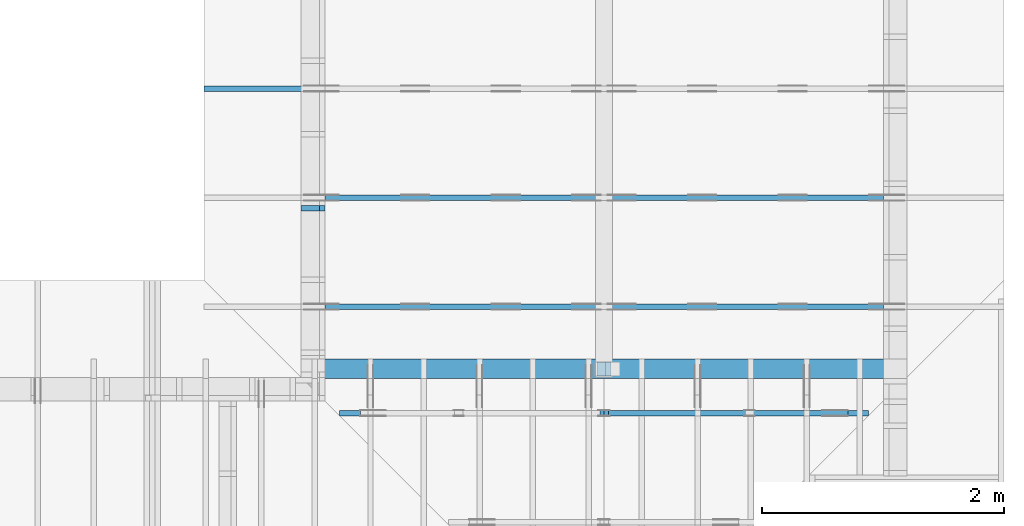
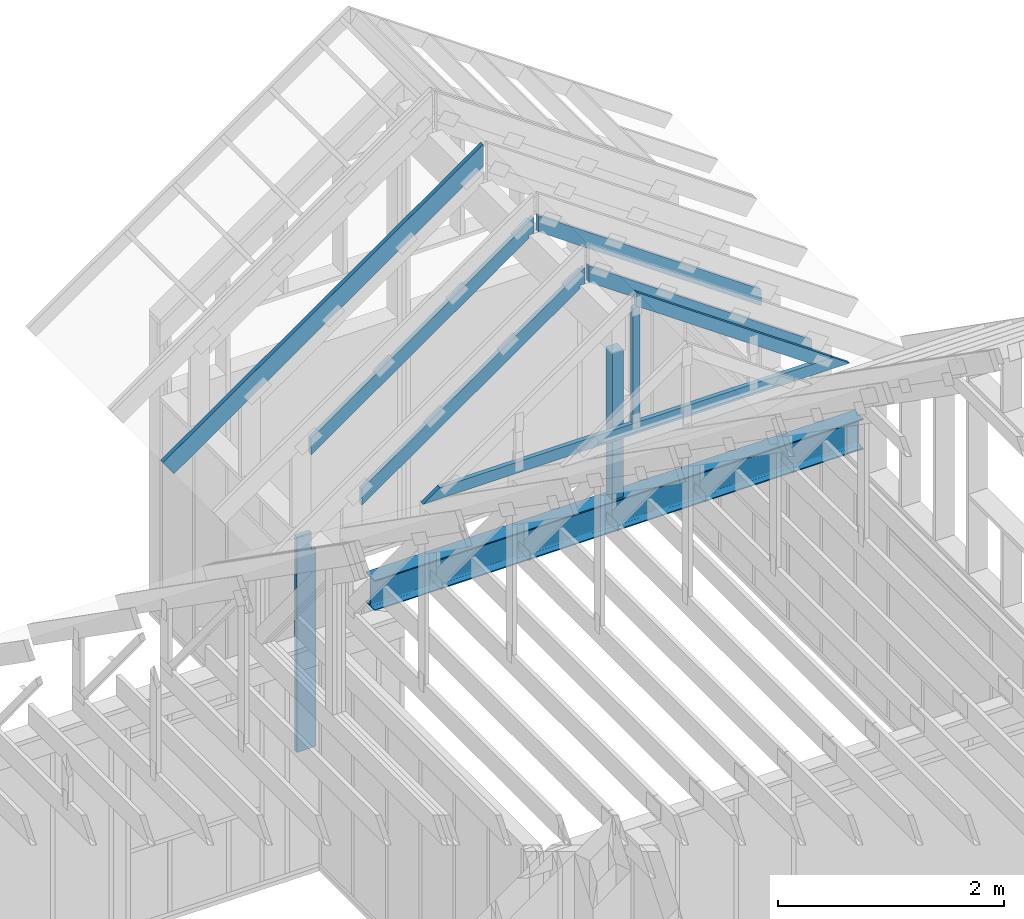
# One storey, part 31 of 70: 11 members, 9 elements without a shape of their own.
"""IFC2X3 building model written with IfcOpenShell, lengths in millimetres."""

from ifc_helpers import new_model, si_unit, frame, origin, origin_with_axes, origin_2d, place, context, project, spatial, faceted_brep, element, aggregate, save


model = new_model("IFC2X3")

# Units and contexts
model_context = context("Model", 3, precision=1e-05, world=origin())
plan_context = context("Plan", 2, precision=1e-05, world=origin_2d())
ifc_project = project(units=[si_unit("LENGTHUNIT", "METRE", prefix="MILLI"), si_unit("AREAUNIT", "SQUARE_METRE"), si_unit("VOLUMEUNIT", "CUBIC_METRE"), si_unit("SOLIDANGLEUNIT", "STERADIAN"), si_unit("PLANEANGLEUNIT", "RADIAN"), si_unit("MASSUNIT", "GRAM"), si_unit("TIMEUNIT", "SECOND"), si_unit("THERMODYNAMICTEMPERATUREUNIT", "DEGREE_CELSIUS"), si_unit("LUMINOUSINTENSITYUNIT", "LUMEN")], contexts=[model_context, plan_context])

# Site, building, storey
site_placement = place(None, origin_with_axes())
site = spatial("IfcSite", under=ifc_project, at=site_placement, CompositionType="ELEMENT")
building_placement = place(site_placement, origin_with_axes())
building = spatial("IfcBuilding", under=site, at=building_placement, Name="Layout 1", CompositionType="ELEMENT")
storey_placement = place(building_placement, origin_with_axes())
storey = spatial("IfcBuildingStorey", under=building, at=storey_placement, Name="Storey 1", CompositionType="ELEMENT", Elevation=0.0)

# Assembly, member
assembly_1_placement = place(storey_placement, frame((12000.0, 8150.0, 4.898425415289509e-15), z_axis=(1.2246063538223773e-16, 1.0, 6.123031769111886e-17), x_axis=(-1.0, 1.2246063538223773e-16, 0.0)))
assembly_1 = element("IfcElementAssembly", 1, at=assembly_1_placement, inside=storey, Name="B3", AssemblyPlace="FACTORY", PredefinedType="TRUSS")
member_1_placement = place(assembly_1_placement, frame((-4.041200967613845e-14, -7.5, -160.0), z_axis=(0.0, 0.0, 1.0), x_axis=(1.0, 0.0, 0.0)))
member_1 = element("IfcMember", 2, at=member_1_placement, Name="G1", context=model_context, shape_type="Brep", body=[
    faceted_brep([(9.796850830579018e-15, 330.0, 0.0), (1.5777218104420236e-30, 330.0, 159.99999999999997), (1.5777218104420236e-30, 318.5, 159.99999999999997), (3.566666005507675e-15, 318.5, 101.74999999999997), (3.851922307918184e-15, 317.88666487320324, 97.0912571881546), (4.117738864727745e-15, 316.0884572681199, 92.74999999999997), (4.346000716872418e-15, 313.22792206135784, 89.02207793864211), (4.521152196349088e-15, 309.5, 86.16154273188008), (4.631257019282926e-15, 305.1587428118454, 84.36333512679674), (4.668811723947815e-15, 300.5, 83.74999999999997), (4.668811723947813e-15, 29.500000000000004, 83.75), (4.631257019282925e-15, 24.841257188154625, 84.36333512679677), (4.5211521963490856e-15, 20.5, 86.1615427318801), (4.346000716872416e-15, 16.772077938642145, 89.02207793864214), (4.1177388647277435e-15, 13.91154273188011, 92.75), (3.851922307918182e-15, 12.11333512679677, 97.09125718815463), (3.566666005507674e-15, 11.5, 101.75), (0.0, 11.5, 160.0), (0.0, 2.930988785010413e-14, 160.0), (9.796850830579018e-15, 2.930988785010413e-14, 0.0), (9.796850830579018e-15, 11.5, 0.0), (6.230184825071344e-15, 11.5, 58.25), (5.944928522660836e-15, 12.11333512679677, 62.90874281184537), (5.6791119658512745e-15, 13.91154273188011, 67.25), (5.450850113706602e-15, 16.772077938642145, 70.97792206135786), (5.2756986342299325e-15, 20.5, 73.8384572681199), (5.1655938112960934e-15, 24.841257188154625, 75.63666487320323), (5.128039106631205e-15, 29.500000000000004, 76.25), (5.128039106631205e-15, 300.5, 76.25), (5.1655938112960934e-15, 305.1587428118454, 75.63666487320323), (5.2756986342299325e-15, 309.5, 73.8384572681199), (5.450850113706602e-15, 313.22792206135784, 70.97792206135786), (5.6791119658512745e-15, 316.0884572681199, 67.25), (5.944928522660836e-15, 317.88666487320324, 62.90874281184537), (6.230184825071344e-15, 318.5, 58.25), (9.796850830579018e-15, 318.5, 0.0), (5000.0, 330.0, 0.0), (5000.0, 330.0, 159.99999999999997), (5000.0, 318.5, 159.99999999999997), (5000.0, 318.5, 101.74999999999997), (5000.0, 317.88666487320324, 97.0912571881546), (5000.0, 316.0884572681199, 92.74999999999997), (5000.0, 313.22792206135784, 89.02207793864211), (5000.0, 309.5, 86.16154273188008), (5000.0, 305.1587428118454, 84.36333512679674), (5000.0, 300.5, 83.74999999999997), (5000.0, 29.500000000000004, 83.75), (5000.0, 24.841257188154625, 84.36333512679677), (5000.0, 20.5, 86.1615427318801), (5000.0, 16.772077938642145, 89.02207793864214), (5000.0, 13.91154273188011, 92.75), (5000.0, 12.11333512679677, 97.09125718815463), (5000.0, 11.5, 101.75), (5000.0, 11.5, 160.0), (5000.0, 2.930988785010413e-14, 160.0), (5000.0, 2.930988785010413e-14, 0.0), (5000.0, 11.5, 0.0), (5000.0, 11.5, 58.25), (5000.0, 12.11333512679677, 62.90874281184537), (5000.0, 13.91154273188011, 67.25), (5000.0, 16.772077938642145, 70.97792206135786), (5000.0, 20.5, 73.8384572681199), (5000.0, 24.841257188154625, 75.63666487320323), (5000.0, 29.500000000000004, 76.25), (5000.0, 300.5, 76.25), (5000.0, 305.1587428118454, 75.63666487320323), (5000.0, 309.5, 73.8384572681199), (5000.0, 313.22792206135784, 70.97792206135786), (5000.0, 316.0884572681199, 67.25), (5000.0, 317.88666487320324, 62.90874281184537), (5000.0, 318.5, 58.25), (5000.0, 318.5, 0.0), (5000.0, 330.0, 0.0), (9.796850830579018e-15, 330.0, 0.0), (9.796850830579018e-15, 318.5, 0.0), (5000.0, 318.5, 0.0), (5000.0, 11.5, 0.0), (9.796850830579018e-15, 11.5, 0.0), (9.796850830579018e-15, 0.0, 0.0), (5000.0, 0.0, 0.0), (5000.0, 11.499999999999082, 5.620633949699709e-29), (5000.0, 11.499999999999085, 58.25), (9.796850830579018e-15, 11.500000000000004, 58.25), (9.796850830579018e-15, 11.5, 0.0), (5000.0, 11.499999999999087, 101.75), (5000.0, 11.49999999999909, 160.0), (9.79685083057902e-15, 11.50000000000001, 160.0), (9.79685083057902e-15, 11.500000000000007, 101.75), (5000.0, 11.499999999999112, 58.250000000000114), (5000.0, 12.113335126795883, 62.908742811845485), (6.3428489390660134e-15, 12.113335126796786, 62.90874281184537), (6.230184825071347e-15, 11.500000000000014, 58.25), (5000.0, 12.113335126795976, 62.9087428118457), (5000.0, 13.911542731879313, 67.25000000000031), (6.275242991462349e-15, 13.911542731880102, 67.25), (5.944928522660833e-15, 12.11333512679676, 62.90874281184538), (5000.0, 13.911542731879532, 67.25000000000045), (5000.0, 16.77207793864157, 70.9779220613583), (6.204566404281285e-15, 16.772077938642145, 70.97792206135786), (5.6791119658512745e-15, 13.911542731880107, 67.25), (5000.0, 16.7720779386418, 70.9779220613583), (5000.0, 20.49999999999966, 73.83845726812035), (6.135635670140619e-15, 20.499999999999993, 73.8384572681199), (5.4508501137066016e-15, 16.77207793864214, 70.97792206135787), (5000.0, 20.49999999999987, 73.83845726812021), (5000.0, 24.841257188154497, 75.63666487320354), (6.073148304658615e-15, 24.841257188154625, 75.63666487320322), (5.275698634229933e-15, 20.500000000000004, 73.8384572681199), (5000.0, 24.841257188154607, 75.63666487320337), (5000.0, 29.499999999999986, 76.25000000000014), (6.0213627185276195e-15, 29.500000000000007, 76.25000000000001), (5.165593811296093e-15, 24.84125718815463, 75.63666487320324), (5000.0, 300.5, 76.25), (5.128039106631205e-15, 300.5, 76.25), (5.128039106631205e-15, 29.500000000000004, 76.25), (5000.0, 29.500000000000004, 76.25), (5.413295409041716e-15, 305.15874281184546, 75.63666487320333), (5000.0, 300.5, 76.25000000000007), (5000.0, 305.1587428118454, 75.6366648732033), (5.4314103681056574e-15, 309.50000000000006, 73.83845726811997), (5000.0, 305.15874281184534, 75.6366648732032), (5000.0, 309.49999999999994, 73.83845726811988), (5.503960486374606e-15, 313.22792206135784, 70.97792206135786), (5000.0, 309.4999999999999, 73.83845726811974), (5000.0, 313.22792206135773, 70.9779220613577), (5.626001593183277e-15, 316.0884572681199, 67.25), (5000.0, 313.2279220613577, 70.9779220613577), (5000.0, 316.0884572681197, 67.24999999999984), (5.789216788785118e-15, 317.8866648732033, 62.9087428118454), (5000.0, 316.0884572681197, 67.24999999999991), (5000.0, 317.8866648732031, 62.90874281184529), (5.982483227325724e-15, 318.5, 58.25), (5000.0, 317.88666487320296, 62.90874281184533), (5000.0, 318.4999999999997, 58.24999999999996), (6.230184825071344e-15, 318.5, 0.0), (6.230184825071344e-15, 318.5, 58.25), (5000.0, 318.4999999999997, 58.25), (5000.0, 318.4999999999997, -1.8932661725304283e-29), (6.230184825071344e-15, 318.5, 101.74999999999997), (6.2301848250713435e-15, 318.5, 159.99999999999997), (5000.0, 318.49999999999966, 159.99999999999997), (5000.0, 318.4999999999997, 101.74999999999997), (5000.0, 329.9999999999991, 5.679798517591285e-29), (5000.0, 329.9999999999991, 159.99999999999997), (9.79685083057902e-15, 330.0, 159.99999999999997), (9.796850830579018e-15, 330.0, 0.0), (0.0, 330.0, 159.99999999999997), (5000.0, 330.0, 160.0000000000006), (5000.0, 318.5, 160.0000000000006), (0.0, 318.5, 159.99999999999997), (3.1554436208840472e-30, 11.500000000000032, 159.99999999999997), (5000.0, 11.500000000000032, 160.0000000000006), (5000.0, 2.930988785010413e-14, 160.0000000000006), (3.1554436208840472e-30, 2.930988785010413e-14, 159.99999999999997), (3.5291113008427863e-15, 317.88666487320324, 97.0912571881546), (5000.0, 318.4999999999997, 101.75), (5000.0, 317.88666487320296, 97.09125718815466), (3.7418174849843445e-15, 316.0884572681199, 92.74999999999999), (5000.0, 317.886664873203, 97.09125718815473), (5000.0, 316.08845726811967, 92.7500000000001), (3.94258738525107e-15, 313.2279220613578, 89.02207793864211), (5000.0, 316.08845726811967, 92.7500000000001), (5000.0, 313.2279220613576, 89.02207793864228), (4.1177388647277396e-15, 309.5, 86.16154273188016), (5000.0, 313.22792206135773, 89.02207793864235), (5000.0, 309.49999999999983, 86.1615427318803), (4.255335639539532e-15, 305.1587428118455, 84.36333512679664), (5000.0, 309.50000000000006, 86.16154273188008), (5000.0, 305.15874281184546, 84.36333512679674), (4.346000716872412e-15, 300.49999999999994, 83.74999999999986), (5000.0, 305.1587428118454, 84.36333512679667), (5000.0, 300.49999999999994, 83.74999999999989), (4.66881172394781e-15, 300.5, 83.75), (5000.0, 300.5, 83.75000000000061), (5000.0, 29.500000000000004, 83.75000000000061), (4.668811723947813e-15, 29.500000000000004, 83.75), (5000.0, 29.499999999999986, 83.74999999999989), (5000.0, 24.84125718815461, 84.36333512679666), (3.8130428167162864e-15, 24.84125718815463, 84.36333512679677), (4.6688117239478125e-15, 29.500000000000007, 83.75), (5000.0, 24.841257188154493, 84.36333512679647), (5000.0, 20.499999999999872, 86.1615427318798), (3.833807348854242e-15, 20.500000000000007, 86.16154273188012), (4.631257019282925e-15, 24.84125718815463, 84.3633351267968), (5000.0, 20.499999999999666, 86.16154273187966), (5000.0, 16.772077938641814, 89.0220779386417), (3.8363666399150676e-15, 16.77207793864215, 89.02207793864214), (4.521152196349085e-15, 20.500000000000004, 86.1615427318801), (5000.0, 16.77207793864156, 89.0220779386417), (5000.0, 13.911542731879528, 92.74999999999955), (3.820546278442408e-15, 13.911542731880111, 92.74999999999999), (4.346000716872415e-15, 16.772077938642134, 89.02207793864214), (5000.0, 13.91154273187933, 92.74999999999969), (5000.0, 12.113335126795995, 97.09125718815432), (3.7874243959262256e-15, 12.113335126796777, 97.09125718815463), (4.117738864727741e-15, 13.911542731880111, 92.75000000000003), (5000.0, 12.113335126795855, 97.0912571881545), (5000.0, 11.499999999999085, 101.74999999999986), (3.7392581939235136e-15, 11.499999999999988, 101.74999999999999), (3.851922307918181e-15, 12.113335126796759, 97.09125718815461), (-1.794653744552941e-30, 1.0988721892453267e-46, 9.646674802900867e-47), (-2.1918016109641297e-31, 2.573028595742599e-14, 160.0), (5000.0, -2.804213024981683e-13, 160.0), (5000.0, -3.061515884555943e-13, 4.92335494830165e-29)], [[[0, 1, 2, 3, 4, 5, 6, 7, 8, 9, 10, 11, 12, 13, 14, 15, 16, 17, 18, 19, 20, 21, 22, 23, 24, 25, 26, 27, 28, 29, 30, 31, 32, 33, 34, 35]], [[36, 37, 38, 39, 40, 41, 42, 43, 44, 45, 46, 47, 48, 49, 50, 51, 52, 53, 54, 55, 56, 57, 58, 59, 60, 61, 62, 63, 64, 65, 66, 67, 68, 69, 70, 71]], [[72, 73, 74, 75]], [[76, 77, 78, 79]], [[80, 81, 82, 83]], [[84, 85, 86, 87]], [[88, 89, 90, 91]], [[92, 93, 94, 95]], [[96, 97, 98, 99]], [[100, 101, 102, 103]], [[104, 105, 106, 107]], [[108, 109, 110, 111]], [[112, 113, 114, 115]], [[116, 117, 118]], [[119, 120, 121]], [[122, 123, 124]], [[125, 126, 127]], [[128, 129, 130]], [[131, 132, 133]], [[134, 135, 136, 137]], [[138, 139, 140, 141]], [[142, 143, 144, 145]], [[146, 147, 148, 149]], [[150, 151, 152, 153]], [[154, 155, 156]], [[157, 158, 159]], [[160, 161, 162]], [[163, 164, 165]], [[166, 167, 168]], [[169, 170, 171]], [[172, 173, 174, 175]], [[176, 177, 178, 179]], [[180, 181, 182, 183]], [[184, 185, 186, 187]], [[188, 189, 190, 191]], [[192, 193, 194, 195]], [[196, 197, 198, 199]], [[200, 201, 202, 203]]]),
])
aggregate(assembly_1, [member_1])

assembly_2_placement = place(storey_placement, frame((7000.0, 10405.0, 1.3776821480501744e-15), z_axis=(1.2246063538223773e-16, 1.0, 6.123031769111886e-17), x_axis=(-1.0, 1.2246063538223773e-16, 0.0)))
assembly_2 = element("IfcElementAssembly", 3, at=assembly_2_placement, inside=storey, Name="T4", AssemblyPlace="FACTORY", PredefinedType="TRUSS")
member_2_placement = place(assembly_2_placement, frame((-2589.347405088728, 2575.029527277477, -45.00000000000001), z_axis=(0.0, 0.0, 1.0), x_axis=(0.8191520442889916, -0.5735764363510465, 0.0)))
member_2 = element("IfcMember", 4, at=member_2_placement, Name="T11", context=model_context, shape_type="Brep", body=[
    faceted_brep([(4001.0887146659597, 194.99999999844545, 45.0), (0.0, 194.99999999844545, 45.0), (136.5404699499495, 1.8338823792873882e-09, 45.0), (4001.0887146652617, 1.8338823792873882e-09, 45.0), (0.0, 194.99999999844545, 0.0), (4001.0887146659597, 194.99999999844545, 4.899758662186943e-13), (4001.0887146652617, 1.8338823792873882e-09, 4.899758662186089e-13), (136.5404699499495, 1.8338823792873882e-09, 1.6720832705460153e-14), (136.54046994994948, 1.8338823792873882e-09, 7.888609052210118e-31), (136.54046994994948, 1.8338823792873882e-09, 45.0), (4.263256414560601e-14, 195.00000000048556, 45.0), (4.263256414560601e-14, 195.00000000048556, -3.1554436208840472e-30), (4001.0887146652617, 2.7584992468545714e-13, -1.6890378523536798e-29), (4001.0887146652617, 2.786052889815575e-13, 45.0), (136.5404699499495, 1.8338945482590892e-09, 45.0), (136.5404699499495, 1.833891792894793e-09, -5.763981720251638e-31), (4001.0887146652617, 194.99999999844545, -4.2712084852286463e-26), (4001.0887146652617, 194.99999999844545, 45.0), (4001.0887146652617, 0.0, 45.0), (4001.0887146652617, 0.0, 0.0), (0.0, 195.00000000048556, 0.0), (0.0, 195.00000000048556, 45.0), (4001.0887146659597, 194.9999999984455, 45.0), (4001.0887146659597, 194.9999999984455, 3.1554436208840472e-30)], [[[0, 1, 2, 3]], [[4, 5, 6, 7]], [[8, 9, 10, 11]], [[12, 13, 14, 15]], [[16, 17, 18, 19]], [[20, 21, 22, 23]]]),
])
aggregate(assembly_2, [member_2])

assembly_3_placement = place(storey_placement, frame((7000.0, 9505.0, 1.3776821480501744e-15), z_axis=(1.2246063538223773e-16, 1.0, 6.123031769111886e-17), x_axis=(-1.0, 1.2246063538223773e-16, 0.0)))
assembly_3 = element("IfcElementAssembly", 5, at=assembly_3_placement, inside=storey, Name="T4", AssemblyPlace="FACTORY", PredefinedType="TRUSS")
member_3_placement = place(assembly_3_placement, frame((-111.83141672927059, 840.2541561936754, -44.99999999999999), z_axis=(0.0, 0.0, 1.0), x_axis=(-0.819152044288719, 0.5735764363514356, 0.0)))
member_3 = element("IfcMember", 6, at=member_3_placement, Name="SC2", context=model_context, shape_type="Brep", body=[
    faceted_brep([(2786.417998849913, 144.9999999982091, 45.0), (2745.0508206133427, 116.03438996246825, 45.0), (2724.7688821174256, 144.9999999982091, 45.0), (0.0, 144.9999999982091, 45.0), (101.53009304058673, 3.296918293926865e-12, 45.0), (2887.948091889168, 3.296918293926865e-12, 45.0), (0.0, 144.9999999982091, 0.0), (2724.7688821174256, 144.9999999982091, 3.3367692857384953e-13), (2745.0508206133427, 116.03438996246825, 3.36160667648843e-13), (2786.417998849913, 144.9999999982091, 3.412265185796637e-13), (2887.948091889168, 3.296918293926865e-12, 3.536599582836686e-13), (101.53009304058673, 3.296918293926865e-12, 1.2433439704167964e-14), (2786.417998849913, 144.99999999820875, -3.4361342959847526e-29), (2786.417998849913, 144.99999999820875, 45.0), (2887.948091889168, 2.9558577807620168e-12, 45.0), (2887.948091889168, 2.9558577807620168e-12, -3.545226557966541e-29), (2745.0508206133427, 116.03438996246814, -1.262177448353619e-29), (2745.0508206133427, 116.03438996246814, 45.0), (2786.417998849913, 144.99999999820898, 45.0), (2786.417998849913, 144.99999999820898, -1.262177448353619e-29), (2724.7688821174256, 144.99999999824877, 0.0), (2724.7688821174256, 144.99999999824877, 45.0), (2745.0508206133427, 116.03438996246837, 45.0), (2745.0508206133427, 116.03438996246837, 0.0), (0.0, 145.00000000000875, 0.0), (0.0, 145.00000000000875, 45.0), (2724.7688821174256, 144.99999999824857, 45.0), (2724.7688821174256, 144.99999999824857, -1.735493991486226e-29), (101.5300930405867, 0.0, 1.5777218104420236e-30), (101.5300930405867, 0.0, 45.0), (1.4210854715202004e-14, 145.00000000000875, 45.0), (1.4210854715202004e-14, 145.00000000000875, -7.888609052210118e-31), (2887.948091889168, 1.914391789805818e-12, 8.465253706372364e-29), (2887.948091889168, 1.9171471541019185e-12, 45.0), (101.53009304058673, -4.584940287014898e-14, 45.0), (101.53009304058673, -4.860476716624933e-14, 2.976085334892309e-30)], [[[0, 1, 2, 3, 4, 5]], [[6, 7, 8, 9, 10, 11]], [[12, 13, 14, 15]], [[16, 17, 18, 19]], [[20, 21, 22, 23]], [[24, 25, 26, 27]], [[28, 29, 30, 31]], [[32, 33, 34, 35]]]),
])
aggregate(assembly_3, [member_3])

assembly_4_placement = place(storey_placement, frame((7000.0, 8605.0, 1.3776821480501744e-15), z_axis=(1.2246063538223773e-16, 1.0, 6.123031769111886e-17), x_axis=(-1.0, 1.2246063538223773e-16, 0.0)))
assembly_4 = element("IfcElementAssembly", 7, at=assembly_4_placement, inside=storey, Name="T4", AssemblyPlace="FACTORY", PredefinedType="TRUSS")
member_4_placement = place(assembly_4_placement, frame((-111.83141672927059, 840.2541561936754, -44.99999999999999), z_axis=(0.0, 0.0, 1.0), x_axis=(-0.819152044288719, 0.5735764363514356, 0.0)))
member_4 = element("IfcMember", 8, at=member_4_placement, Name="SC2", context=model_context, shape_type="Brep", body=[
    faceted_brep([(2786.417998849913, 144.9999999982091, 45.0), (2745.0508206133427, 116.03438996246825, 45.0), (2724.7688821174256, 144.9999999982091, 45.0), (0.0, 144.9999999982091, 45.0), (101.53009304058673, 3.296918293926865e-12, 45.0), (2887.948091889168, 3.296918293926865e-12, 45.0), (0.0, 144.9999999982091, 0.0), (2724.7688821174256, 144.9999999982091, 3.3367692857384953e-13), (2745.0508206133427, 116.03438996246825, 3.36160667648843e-13), (2786.417998849913, 144.9999999982091, 3.412265185796637e-13), (2887.948091889168, 3.296918293926865e-12, 3.536599582836686e-13), (101.53009304058673, 3.296918293926865e-12, 1.2433439704167964e-14), (2786.417998849913, 144.99999999820875, -3.4361342959847526e-29), (2786.417998849913, 144.99999999820875, 45.0), (2887.948091889168, 2.9558577807620168e-12, 45.0), (2887.948091889168, 2.9558577807620168e-12, -3.545226557966541e-29), (2745.0508206133427, 116.03438996246814, -1.262177448353619e-29), (2745.0508206133427, 116.03438996246814, 45.0), (2786.417998849913, 144.99999999820898, 45.0), (2786.417998849913, 144.99999999820898, -1.262177448353619e-29), (2724.7688821174256, 144.99999999824877, 0.0), (2724.7688821174256, 144.99999999824877, 45.0), (2745.0508206133427, 116.03438996246837, 45.0), (2745.0508206133427, 116.03438996246837, 0.0), (0.0, 145.00000000000875, 0.0), (0.0, 145.00000000000875, 45.0), (2724.7688821174256, 144.99999999824857, 45.0), (2724.7688821174256, 144.99999999824857, -1.735493991486226e-29), (101.5300930405867, 0.0, 1.5777218104420236e-30), (101.5300930405867, 0.0, 45.0), (1.4210854715202004e-14, 145.00000000000875, 45.0), (1.4210854715202004e-14, 145.00000000000875, -7.888609052210118e-31), (2887.948091889168, 1.914391789805818e-12, 8.465253706372364e-29), (2887.948091889168, 1.9171471541019185e-12, 45.0), (101.53009304058673, -4.584940287014898e-14, 45.0), (101.53009304058673, -4.860476716624933e-14, 2.976085334892309e-30)], [[[0, 1, 2, 3, 4, 5]], [[6, 7, 8, 9, 10, 11]], [[12, 13, 14, 15]], [[16, 17, 18, 19]], [[20, 21, 22, 23]], [[24, 25, 26, 27]], [[28, 29, 30, 31]], [[32, 33, 34, 35]]]),
])
aggregate(assembly_4, [member_4])

assembly_5_placement = place(storey_placement, frame((7000.0, 11805.0, -2470.0), z_axis=(-1.0, 1.836909530733566e-16, 6.123031769111886e-17), x_axis=(-1.836909530733566e-16, -1.0, 0.0)))
assembly_5 = element("IfcElementAssembly", 9, at=assembly_5_placement, inside=storey, Name="VE1", AssemblyPlace="FACTORY", PredefinedType="NOTDEFINED")
member_5_placement = place(assembly_5_placement, frame((2387.5000000055006, 2425.0, -195.00000000000003), z_axis=(0.0, 0.0, 1.0), x_axis=(-1.836909530733566e-16, -1.0, 0.0)))
member_5 = element("IfcMember", 10, at=member_5_placement, Name="S11", context=model_context, shape_type="Brep", body=[
    faceted_brep([(0.0, 45.00000000001455, 45.00000000000003), (195.00000000186265, 45.00000000001455, 45.00000000000005), (195.00000000186265, 0.0, 45.00000000000005), (0.0, 0.0, 45.00000000000003), (195.00000000186265, 1.3642420526593924e-12, 2.842170943040401e-14), (195.00000000186265, 1.3642420526593924e-12, 45.00000000000003), (195.00000000186265, 45.00000000001455, 45.00000000000003), (195.00000000186265, 45.00000000001455, 2.842170943040401e-14), (2.7553642961003504e-15, -3.3742366240998114e-31, 45.00000000000003), (1.1939911949768181e-14, -1.4621692037765844e-30, 195.00000000000006), (1.7450640541970662e-14, 45.00000000001455, 195.00000000000006), (8.26609288830283e-15, 45.00000000001455, 45.00000000000003), (2335.0, -4.2891837542628763e-13, 2.842170943040403e-14), (2335.0, -4.1697846347651946e-13, 195.00000000000003), (2.1932538056648764e-30, 1.193991194976818e-14, 195.00000000000003), (5.061354936149717e-31, 2.7553642961003504e-15, 45.00000000000003), (195.00000000186265, -3.306437155354634e-14, 45.00000000000003), (195.00000000186265, -3.5819735849646686e-14, 2.842170943040401e-14), (-1.6871183120499057e-31, 45.00000000001455, 45.00000000000003), (-7.310846018882921e-31, 45.00000000001454, 195.00000000000003), (2335.0, 45.000000000014396, 195.00000000000003), (2335.0, 45.00000000001441, 2.8421709430403998e-14), (195.00000000186265, 45.00000000001454, 2.8421709430404004e-14), (195.00000000186265, 45.00000000001454, 45.00000000000003), (2335.0, 45.00000000001501, 0.0), (2335.0, 45.00000000001501, 195.00000000000003), (2335.0, 1.5006662579253316e-11, 195.00000000000003), (2335.0, 1.5006662579253316e-11, 0.0), (2335.0, 45.00000000001501, 195.00000000000003), (0.0, 45.00000000001501, 195.00000000000003), (0.0, 0.0, 195.00000000000003), (2335.0, 0.0, 195.00000000000003), (195.00000000186265, 45.00000000001455, 5.2301533330168465e-14), (2335.0, 45.00000000001455, 3.143672930479291e-13), (2335.0, 1.5006662579253316e-11, 3.143672930479291e-13), (195.00000000186265, 1.5006662579253316e-11, 5.2301533330168465e-14)], [[[0, 1, 2, 3]], [[4, 5, 6, 7]], [[8, 9, 10, 11]], [[12, 13, 14, 15, 16, 17]], [[18, 19, 20, 21, 22, 23]], [[24, 25, 26, 27]], [[28, 29, 30, 31]], [[32, 33, 34, 35]]]),
])
aggregate(assembly_5, [member_5])

assembly_6_placement = place(storey_placement, frame((12000.0, 8605.0, 1.3776821480501744e-15), z_axis=(1.2246063538223773e-16, 1.0, 6.123031769111886e-17), x_axis=(-1.0, 1.2246063538223773e-16, 0.0)))
assembly_6 = element("IfcElementAssembly", 11, at=assembly_6_placement, inside=storey, Name="T10", AssemblyPlace="FACTORY", PredefinedType="TRUSS")
member_6_placement = place(assembly_6_placement, frame((194.9999999995092, 721.4771097712946, -45.0), z_axis=(0.0, 0.0, 1.0), x_axis=(0.8191520442887201, 0.5735764363514341, 0.0)))
member_6 = element("IfcMember", 12, at=member_6_placement, Name="SC3", context=model_context, shape_type="Brep", body=[
    faceted_brep([(2887.9480918911295, 145.00000000153284, 45.0), (101.53009304036573, 145.00000000153284, 45.0), (0.0, 0.0, 45.0), (2786.417998849739, 0.0, 45.0), (101.53009304036573, 145.00000000153284, 1.24334397041409e-14), (2887.9480918911295, 145.00000000153284, 3.536599582839088e-13), (2786.417998849739, 0.0, 3.412265185796424e-13), (0.0, 0.0, 0.0), (0.0, 0.0, 0.0), (2.257062295911826e-15, -1.5804120338056804e-15, 45.0), (101.53009304036573, 145.00000000000352, 45.0), (101.53009304036573, 145.00000000000352, 0.0), (2786.417998849739, 2.7666982972447333e-10, -8.780400618266663e-29), (2786.417998849739, 2.7667258508876943e-10, 45.0), (-2.7358643640174327e-28, 2.755364296100349e-15, 45.0), (0.0, 0.0, 0.0), (2887.9480918911295, 145.00000000153273, -1.0940736677918797e-29), (2887.9480918911295, 145.00000000153273, 45.0), (2786.417998849739, 2.75349520961754e-10, 45.0), (2786.417998849739, 2.75349520961754e-10, -9.849814058077961e-30), (101.53009304036573, 145.00000000000352, 0.0), (101.53009304036573, 145.0000000000035, 45.0), (2887.9480918911295, 145.00000000153278, 45.0), (2887.9480918911295, 145.00000000153278, -1.5777218104420236e-30)], [[[0, 1, 2, 3]], [[4, 5, 6, 7]], [[8, 9, 10, 11]], [[12, 13, 14, 15]], [[16, 17, 18, 19]], [[20, 21, 22, 23]]]),
])
aggregate(assembly_6, [member_6])

assembly_7_placement = place(storey_placement, frame((12000.0, 9505.0, 1.3776821480501744e-15), z_axis=(1.2246063538223773e-16, 1.0, 6.123031769111886e-17), x_axis=(-1.0, 1.2246063538223773e-16, 0.0)))
assembly_7 = element("IfcElementAssembly", 13, at=assembly_7_placement, inside=storey, Name="T10", AssemblyPlace="FACTORY", PredefinedType="TRUSS")
member_7_placement = place(assembly_7_placement, frame((194.9999999995092, 721.4771097712946, -45.0), z_axis=(0.0, 0.0, 1.0), x_axis=(0.8191520442887201, 0.5735764363514341, 0.0)))
member_7 = element("IfcMember", 14, at=member_7_placement, Name="SC3", context=model_context, shape_type="Brep", body=[
    faceted_brep([(2887.9480918911295, 145.00000000153284, 45.0), (101.53009304036573, 145.00000000153284, 45.0), (0.0, 0.0, 45.0), (2786.417998849739, 0.0, 45.0), (101.53009304036573, 145.00000000153284, 1.24334397041409e-14), (2887.9480918911295, 145.00000000153284, 3.536599582839088e-13), (2786.417998849739, 0.0, 3.412265185796424e-13), (0.0, 0.0, 0.0), (0.0, 0.0, 0.0), (2.257062295911826e-15, -1.5804120338056804e-15, 45.0), (101.53009304036573, 145.00000000000352, 45.0), (101.53009304036573, 145.00000000000352, 0.0), (2786.417998849739, 2.7666982972447333e-10, -8.780400618266663e-29), (2786.417998849739, 2.7667258508876943e-10, 45.0), (-2.7358643640174327e-28, 2.755364296100349e-15, 45.0), (0.0, 0.0, 0.0), (2887.9480918911295, 145.00000000153273, -1.0940736677918797e-29), (2887.9480918911295, 145.00000000153273, 45.0), (2786.417998849739, 2.75349520961754e-10, 45.0), (2786.417998849739, 2.75349520961754e-10, -9.849814058077961e-30), (101.53009304036573, 145.00000000000352, 0.0), (101.53009304036573, 145.0000000000035, 45.0), (2887.9480918911295, 145.00000000153278, 45.0), (2887.9480918911295, 145.00000000153278, -1.5777218104420236e-30)], [[[0, 1, 2, 3]], [[4, 5, 6, 7]], [[8, 9, 10, 11]], [[12, 13, 14, 15]], [[16, 17, 18, 19]], [[20, 21, 22, 23]]]),
])
aggregate(assembly_7, [member_7])

assembly_8_placement = place(storey_placement, frame((9512.499999999996, 8012.5, 3.5207432672393346e-15), z_axis=(0.0, -1.0, 6.123031769111886e-17), x_axis=(1.0, 0.0, 0.0)))
assembly_8 = element("IfcElementAssembly", 15, at=assembly_8_placement, inside=storey, Name="P1", AssemblyPlace="FACTORY", PredefinedType="TRUSS")
member_8_placement = place(assembly_8_placement, frame((45.0, 322.5, -115.0), z_axis=(0.0, 0.0, 1.0), x_axis=(6.123031769111886e-17, 1.0, 0.0)))
member_8 = element("IfcMember", 16, at=member_8_placement, Name="E1", context=model_context, shape_type="Brep", body=[
    faceted_brep([(1592.2008157372543, 115.00000000000009, 115.0), (0.0, 115.00000000000009, 115.0), (0.0, 0.0, 115.0), (1592.2008157372543, 0.0, 115.0), (0.0, 115.00000000000009, 0.0), (1592.2008157372543, 115.00000000000009, 1.9498192355130137e-13), (1592.2008157372543, 0.0, 1.9498192355130137e-13), (0.0, 0.0, 0.0), (0.0, 0.0, 0.0), (7.041486534478669e-15, -8.62304915047729e-31, 115.0), (2.1124459603436008e-14, 115.0, 115.0), (1.4082973068957338e-14, 115.0, -8.62304915047729e-31), (1592.2008157372543, -2.9247288532695207e-13, 2.3564086152289446e-29), (1592.2008157372543, -2.854313987924734e-13, 115.0), (1.2934573725715935e-30, 7.041486534478669e-15, 115.0), (0.0, 0.0, 0.0), (1592.2008157372543, 115.00000000000009, 0.0), (1592.2008157372543, 115.00000000000009, 115.0), (1592.2008157372543, 9.237055564881302e-14, 115.0), (1592.2008157372543, 9.237055564881302e-14, 0.0), (0.0, 115.0, 0.0), (7.888609052210118e-31, 115.0, 115.0), (1592.2008157372543, 115.00000000000026, 115.0), (1592.2008157372543, 115.00000000000026, 1.0255191767873153e-29)], [[[0, 1, 2, 3]], [[4, 5, 6, 7]], [[8, 9, 10, 11]], [[12, 13, 14, 15]], [[16, 17, 18, 19]], [[20, 21, 22, 23]]]),
])
aggregate(assembly_8, [member_8])

# Assembly, members
assembly_9_placement = place(storey_placement, frame((7294.999999999998, 7682.5, 1206.561223771864), z_axis=(0.0, -1.0, 6.123031769111886e-17), x_axis=(1.0, 0.0, 0.0)))
assembly_9 = element("IfcElementAssembly", 17, at=assembly_9_placement, inside=storey, Name="SB1", AssemblyPlace="FACTORY", PredefinedType="TRUSS")
member_9_placement = place(assembly_9_placement, frame((2136.1708276373142, 1445.6593764377376, -45.00000000000001), z_axis=(0.0, 0.0, 1.0), x_axis=(0.8191520442889916, -0.5735764363510465, 0.0)))
member_9 = element("IfcMember", 18, at=member_9_placement, Name="T19", context=model_context, shape_type="Brep", body=[
    faceted_brep([(2455.1269244979235, 120.00000000039608, 45.0), (0.0, 120.00000000039608, 45.0), (84.02490458540694, 6.320988177321851e-10, 45.0), (2283.7491636883037, 6.320988177321851e-10, 45.0), (0.0, 120.00000000039608, 0.0), (2455.1269244979235, 120.00000000039608, 3.006564031180549e-13), (2283.7491636883037, 6.320988177321851e-10, 2.796693736389237e-13), (84.02490458540694, 6.320988177321851e-10, 1.0289743203460834e-14), (84.02490458540692, 6.320775014501123e-10, 1.5777218104420236e-30), (84.02490458540692, 6.320775014501123e-10, 45.0), (2.842170943040401e-14, 120.00000000097589, 45.0), (2.842170943040401e-14, 120.00000000097589, -2.3665827156630354e-30), (2283.7491636883037, -1.3698807461350582e-12, 8.38782332848013e-29), (2283.7491636883037, -1.3671253818389579e-12, 45.0), (84.02490458540694, 6.320511717210511e-10, 45.0), (84.02490458540694, 6.32048416356755e-10, 3.086092229660856e-30), (2455.126924497923, 120.00000000039608, 2.802596928649634e-45), (2455.126924497923, 120.00000000039608, 45.0), (2283.7491636883033, 2.2737367544323206e-13, 45.0), (2283.7491636883033, 2.2737367544323206e-13, -1.2621774483536186e-29), (0.0, 120.00000000097589, 0.0), (0.0, 120.00000000097589, 45.0), (2455.1269244979235, 120.00000000039624, 45.0), (2455.1269244979235, 120.00000000039624, 9.466330862652142e-30)], [[[0, 1, 2, 3]], [[4, 5, 6, 7]], [[8, 9, 10, 11]], [[12, 13, 14, 15]], [[16, 17, 18, 19]], [[20, 21, 22, 23]]]),
])
member_10_placement = place(assembly_9_placement, frame((4387.500000000931, 135.7546696094791, -45.0), z_axis=(0.0, 0.0, 1.0), x_axis=(-1.0, 1.2246063538223773e-16, 0.0)))
member_10 = element("IfcMember", 19, at=member_10_placement, Name="B4", context=model_context, shape_type="Brep", body=[
    faceted_brep([(4365.000000000931, 120.00000000000003, 45.0), (0.0, 120.00000000000003, 45.0), (171.3777608089149, 9.308394055551616e-10, 45.0), (4193.622239192016, 9.308394055551616e-10, 45.0), (0.0, 120.00000000000003, 0.0), (4365.000000000931, 120.00000000000003, 5.345406734435818e-13), (4193.622239192016, 9.308394055551616e-10, 5.135536439645369e-13), (171.3777608089149, 9.308394055551616e-10, 2.0987029479044878e-14), (171.37776080891484, 9.307399295721552e-10, 6.310887241768095e-30), (171.37776080891484, 9.307399295721552e-10, 45.0), (3.552713678800501e-14, 120.00000000093085, 45.0), (3.552713678800501e-14, 120.00000000093085, -3.944304526105059e-30), (4193.622239192016, -2.412915564757205e-12, 1.4774358659193017e-28), (4193.622239192016, -2.4101602004611047e-12, 45.0), (171.3777608089149, 9.307435540247679e-10, 45.0), (171.3777608089149, 9.307407986604718e-10, 6.037731488392043e-30), (4365.000000000931, 120.00000000000045, -2.524354896707238e-29), (4365.000000000931, 120.00000000000045, 45.0), (4193.622239192016, 2.2737367544323206e-13, 45.0), (4193.622239192016, 2.2737367544323206e-13, -2.524354896707238e-29), (0.0, 120.00000000093081, 0.0), (0.0, 120.00000000093081, 45.0), (4365.000000000931, 120.00000000000105, 45.0), (4365.000000000931, 120.00000000000105, 6.310887241768094e-29)], [[[0, 1, 2, 3]], [[4, 5, 6, 7]], [[8, 9, 10, 11]], [[12, 13, 14, 15]], [[16, 17, 18, 19]], [[20, 21, 22, 23]]]),
])
member_11_placement = place(assembly_9_placement, frame((2240.0, 135.75466960900584, -45.0), z_axis=(0.0, 0.0, 1.0), x_axis=(6.123031769111886e-17, 1.0, 0.0)))
member_11 = element("IfcMember", 20, at=member_11_placement, Name="W9", context=model_context, shape_type="Brep", body=[
    faceted_brep([(1237.202737655086, 70.0, 45.0), (1.6200374375330284e-11, 70.0, 45.0), (0.0, 0.0, 45.0), (1237.2027376550604, 0.0, 45.0), (1261.7100014924154, 35.0, 45.0), (1.6200374375330284e-11, 70.0, 1.9839081394330692e-27), (1237.202737655086, 70.0, 1.515086333498858e-13), (1261.7100014924154, 35.0, 1.545098084508853e-13), (1237.2027376550604, 0.0, 1.5150863334988267e-13), (0.0, 0.0, 0.0), (0.0, 0.0, 0.0), (2.755364296100349e-15, -6.366237512766345e-28, 45.0), (1.6176174847315136e-11, 70.0, 45.0), (1.6173419483019036e-11, 70.0, 1.6504566195476348e-30), (1237.2027376550604, -2.2726295002482402e-13, 1.3915382629440843e-29), (1237.2027376550604, -2.2450758572872367e-13, 45.0), (5.061354936149714e-31, 2.755364296100349e-15, 45.0), (0.0, 0.0, 0.0), (1261.7100014924156, 35.000000000000114, 0.0), (1261.7100014924156, 35.000000000000114, 45.0), (1237.2027376550607, 1.1368683772161603e-13, 45.0), (1237.2027376550607, 1.1368683772161603e-13, 0.0), (1237.202737655086, 70.0, 0.0), (1237.202737655086, 70.0, 45.0), (1261.7100014924154, 35.0, 45.0), (1261.7100014924154, 35.0, 1.262177448353619e-29), (1.6200374375330284e-11, 70.0, 0.0), (1.6200374375330284e-11, 70.0, 45.0), (1237.202737655086, 69.99999999999991, 45.0), (1237.202737655086, 69.99999999999993, -4.733165431326071e-30)], [[[0, 1, 2, 3, 4]], [[5, 6, 7, 8, 9]], [[10, 11, 12, 13]], [[14, 15, 16, 17]], [[18, 19, 20, 21]], [[22, 23, 24, 25]], [[26, 27, 28, 29]]]),
])
aggregate(assembly_9, [member_9, member_10, member_11])

save(model, "model.ifc")
